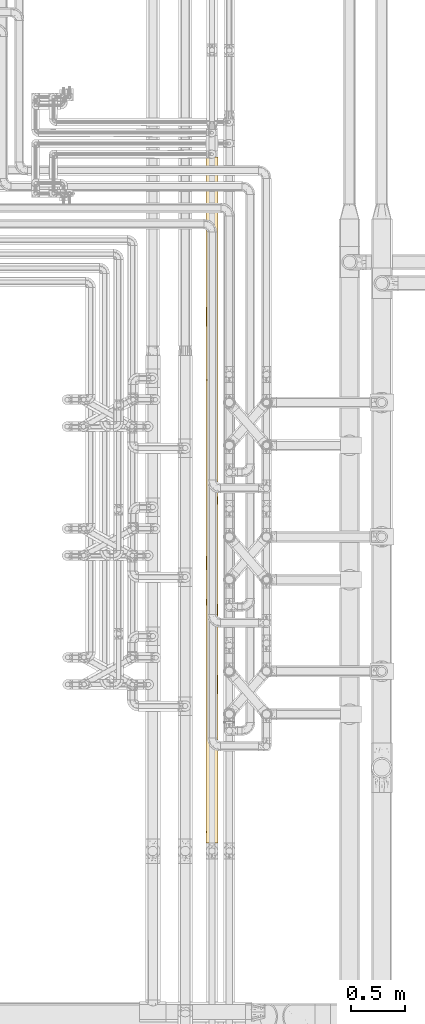
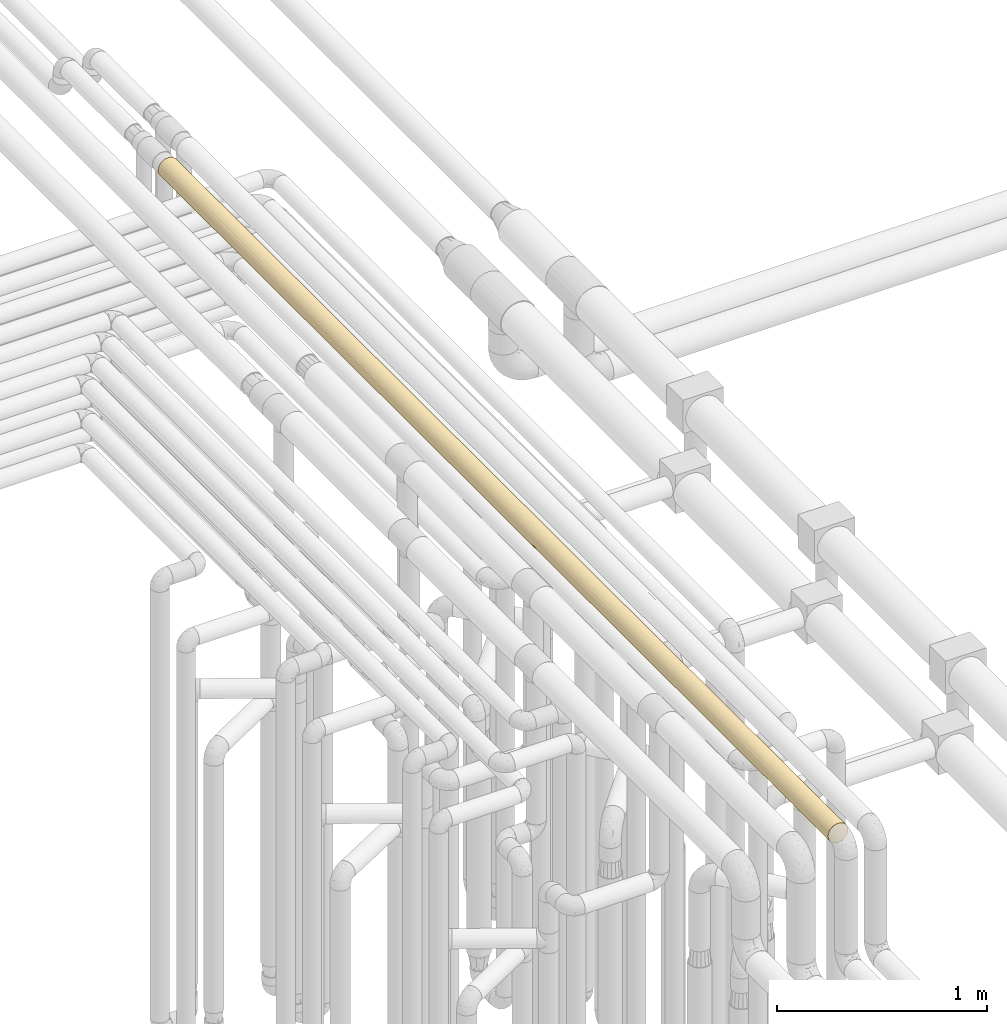
# One storey, part 36 of 827: 1 covering.
"""IFC2X3 building model written with IfcOpenShell, lengths in millimetres."""

import ifcopenshell
import ifcopenshell.guid

model = None  # the IFC model being written
_history = None  # IfcOwnerHistory: only IFC2X3 demands one
_inside = {}  # id of a spatial element -> (the spatial element, [elements in it])
_under = {}  # id of a project, library or spatial element -> (it, [spatial elements below it])
_declared = {}  # id of a project -> (the project, [libraries it declares])
_typed = {}  # id of a type object -> (the type object, [elements of that type])
_made_of = {}  # id of a material, layer set ... -> (it, [elements and type objects made of it])


def new_model(schema):
    """Start an empty IFC model of exactly this schema.

    Asked for "IFC4X3", IfcOpenShell would pick the latest addendum, in which some entities
    have other attributes; the version numbers below select the first issue.
    IFC2X3 requires an IfcOwnerHistory on every rooted entity: one is made here for all.
    """
    global model, _history
    if schema == "IFC4X3":
        model = ifcopenshell.file(schema_version=(4, 3, 0, 0))
    else:
        model = ifcopenshell.file(schema=schema)
    _inside.clear()
    _under.clear()
    _declared.clear()
    _typed.clear()
    _made_of.clear()
    _history = None
    if model.schema == "IFC2X3":
        org = make("IfcOrganization", Name="unknown")
        user = make(
            "IfcPersonAndOrganization",
            ThePerson=make("IfcPerson", FamilyName="unknown"),
            TheOrganization=org,
        )
        app = make(
            "IfcApplication",
            ApplicationDeveloper=org,
            Version="unknown",
            ApplicationFullName="unknown",
            ApplicationIdentifier="unknown",
        )
        _history = make(
            "IfcOwnerHistory",
            OwningUser=user,
            OwningApplication=app,
            ChangeAction="ADDED",
            CreationDate=0,
        )
    return model


def make(cls, **values):
    """One entity of the class cls with the attributes given. An attribute that is None is left unset."""
    return model.create_entity(
        cls, **{name: value for name, value in values.items() if value is not None}
    )


def entity(cls, *values):
    """Any entity or typed value of the class cls, its attributes in the order of the schema. None: left unset."""
    e = model.create_entity(cls)
    for i, value in enumerate(values):
        if value is not None:
            e[i] = value
    return e


def rooted(cls, **values):
    """An entity with a GlobalId (a new one), such as an element, a storey or a relation."""
    return make(cls, GlobalId=ifcopenshell.guid.new(), OwnerHistory=_history, **values)


def si_unit(unit_type, name, prefix=None):
    """IfcSIUnit, for example si_unit("LENGTHUNIT", "METRE", prefix="MILLI")."""
    return make("IfcSIUnit", UnitType=unit_type, Prefix=prefix, Name=name)


def converted_unit(unit_type, name, factor, base, dimensions=None, offset=None):
    """IfcConversionBasedUnit, such as the inch: factor (a typed value) times the base unit."""
    return make(
        "IfcConversionBasedUnit"
        if offset is None
        else "IfcConversionBasedUnitWithOffset",
        ConversionOffset=offset,
        Dimensions=None
        if dimensions is None
        else entity("IfcDimensionalExponents", *dimensions),
        UnitType=unit_type,
        Name=name,
        ConversionFactor=make(
            "IfcMeasureWithUnit", ValueComponent=factor, UnitComponent=base
        ),
    )


def derived_unit(unit_type, elements):
    """IfcDerivedUnit: a product of units, each with its exponent."""
    return make(
        "IfcDerivedUnit",
        Elements=[
            make("IfcDerivedUnitElement", Unit=unit, Exponent=power)
            for unit, power in elements
        ],
        UnitType=unit_type,
    )


def assignment(units):
    """IfcUnitAssignment: the units of a project."""
    return None if units is None else make("IfcUnitAssignment", Units=units)


def point(xyz):
    """IfcCartesianPoint."""
    return None if xyz is None else make("IfcCartesianPoint", Coordinates=xyz)


def direction(xyz):
    """IfcDirection."""
    return None if xyz is None else make("IfcDirection", DirectionRatios=xyz)


def frame(location, z_axis=None, x_axis=None):
    """IfcAxis2Placement3D, a coordinate frame: its origin and axes. An axis left out is left unset."""
    return make(
        "IfcAxis2Placement3D",
        Location=point(location),
        Axis=direction(z_axis),
        RefDirection=direction(x_axis),
    )


def origin():
    """The frame at (0, 0, 0) with its axes left unset."""
    return frame((0.0, 0.0, 0.0))


def place(relative_to, where):
    """IfcLocalPlacement: puts the frame where relative to a parent placement (None: the world)."""
    return make(
        "IfcLocalPlacement", PlacementRelTo=relative_to, RelativePlacement=where
    )


def context(
    kind, dimensions, precision=None, world=None, true_north=None, identifier=None
):
    """IfcGeometricRepresentationContext, for example the 3D "Model" context."""
    return make(
        "IfcGeometricRepresentationContext",
        ContextIdentifier=identifier,
        ContextType=kind,
        CoordinateSpaceDimension=dimensions,
        Precision=precision,
        WorldCoordinateSystem=world,
        TrueNorth=true_north,
    )


def subcontext(parent, identifier, kind, view, scale=None):
    """IfcGeometricRepresentationSubContext, for example "Body" below "Model"."""
    return make(
        "IfcGeometricRepresentationSubContext",
        ContextIdentifier=identifier,
        ContextType=kind,
        ParentContext=parent,
        TargetScale=scale,
        TargetView=view,
    )


def project(units=None, contexts=None):
    """IfcProject with its units and contexts."""
    return rooted(
        "IfcProject",
        Name="project",
        RepresentationContexts=contexts,
        UnitsInContext=assignment(units),
    )


def spatial(cls, under=None, at=None, **own):
    """A site, building, storey or space (cls), placed at a placement, below another one or the project."""
    s = rooted(cls, ObjectPlacement=at, **own)
    if under is not None:
        _under.setdefault(under.id(), (under, []))[1].append(s)
    return s


def faces_of(points, faces, orient=None, outer=None):
    """IfcFace entities. A face is a list of loops; a loop is a list of indices into points, from 0.

    orient and outer hold one flag for each loop. By default every Orientation is true, the
    first loop of a face is its IfcFaceOuterBound and the others are IfcFaceBound.
    """
    made = []
    for i, loops in enumerate(faces):
        bounds = []
        for j, loop in enumerate(loops):
            is_outer = j == 0 if outer is None else outer[i][j]
            bounds.append(
                make(
                    "IfcFaceOuterBound" if is_outer else "IfcFaceBound",
                    Bound=make("IfcPolyLoop", Polygon=[points[k] for k in loop]),
                    Orientation=True if orient is None else orient[i][j],
                )
            )
        made.append(make("IfcFace", Bounds=bounds))
    return made


def faceted_brep(points, faces, orient=None, outer=None, voids=None):
    """IfcFacetedBrep: a solid bounded by flat faces; with voids (closed shells), ...WithVoids."""
    shared = [point(p) for p in points]
    hull = make("IfcClosedShell", CfsFaces=faces_of(shared, faces, orient, outer))
    if voids is None:
        return make("IfcFacetedBrep", Outer=hull)
    return make(
        "IfcFacetedBrepWithVoids",
        Outer=hull,
        Voids=[
            make(cls, CfsFaces=faces_of(shared, fs, o, b)) for cls, fs, o, b in voids
        ],
    )


def shape(context_of_items, identifier, shape_type, items):
    """IfcShapeRepresentation: the items that make up one representation, for example the "Body"."""
    return make(
        "IfcShapeRepresentation",
        ContextOfItems=context_of_items,
        RepresentationIdentifier=identifier,
        RepresentationType=shape_type,
        Items=items,
    )


def made_of(thing, what):
    """Note that an element or type object is made of a material, layer set ...; save() writes the relation."""
    if what is not None:
        _made_of.setdefault(what.id(), (what, []))[1].append(thing)
    return thing


def element(
    cls,
    number,
    at=None,
    inside=None,
    cuts=None,
    type_object=None,
    material=None,
    context=None,
    identifier="Body",
    shape_type=None,
    held_by="IfcProductDefinitionShape",
    body=None,
    shapes=None,
    **own,
):
    """One element of the class cls, such as IfcWall. Its Tag is "e" and its number.

    at: its placement. inside: the storey or other place that contains it. cuts: it is an
    opening in that element (IfcRelVoidsElement). A single representation is given by context,
    identifier, shape_type and body (its items); several are given by shapes. held_by: the class
    of the entity that holds the representations. save() writes the other relations.
    """
    e = rooted(cls, Tag="e%d" % number, ObjectPlacement=at, **own)
    if body is not None:
        shapes = [shape(context, identifier, shape_type, body)]
    if shapes is not None:
        e.Representation = make(held_by, Representations=shapes)
    if inside is not None:
        _inside.setdefault(inside.id(), (inside, []))[1].append(e)
    if cuts is not None:
        rooted(
            "IfcRelVoidsElement", RelatingBuildingElement=cuts, RelatedOpeningElement=e
        )
    if type_object is not None:
        _typed.setdefault(type_object.id(), (type_object, []))[1].append(e)
    return made_of(e, material)


def aggregate(whole, parts):
    """IfcRelAggregates: a whole, such as a stair, and the parts it consists of."""
    return rooted("IfcRelAggregates", RelatingObject=whole, RelatedObjects=parts)


def save(model, path):
    """Write the relations noted so far, then the file.

    IfcRelAggregates (storeys below a building ...), IfcRelContainedInSpatialStructure (elements
    in a storey), IfcRelDefinesByType, IfcRelAssociatesMaterial and IfcRelDeclares: one each for
    every whole, place, type object, material and project.
    """
    for whole, parts in _under.values():
        aggregate(whole, parts)
    for where, things in _inside.values():
        rooted(
            "IfcRelContainedInSpatialStructure",
            RelatedElements=things,
            RelatingStructure=where,
        )
    for kind, things in _typed.values():
        rooted("IfcRelDefinesByType", RelatedObjects=things, RelatingType=kind)
    for what, things in _made_of.values():
        rooted("IfcRelAssociatesMaterial", RelatedObjects=things, RelatingMaterial=what)
    for by, libraries in _declared.values():
        rooted("IfcRelDeclares", RelatingContext=by, RelatedDefinitions=libraries)
    model.write(path)


model = new_model("IFC2X3")

# Units and contexts
model_context = context("Model", 3, precision=0.01, world=origin(), true_north=direction((6.12303176911189e-17, 1.0)))
body_context = subcontext(model_context, "Body", "Model", "MODEL_VIEW")
ifc_project = project(units=[si_unit("LENGTHUNIT", "METRE", prefix="MILLI"), si_unit("AREAUNIT", "SQUARE_METRE"), si_unit("VOLUMEUNIT", "CUBIC_METRE"), converted_unit("PLANEANGLEUNIT", "DEGREE", entity("IfcRatioMeasure", 0.0174532925199433), si_unit("PLANEANGLEUNIT", "RADIAN"), dimensions=[0, 0, 0, 0, 0, 0, 0]), si_unit("MASSUNIT", "GRAM", prefix="KILO"), derived_unit("MASSDENSITYUNIT", [(si_unit("MASSUNIT", "GRAM", prefix="KILO"), 1), (si_unit("LENGTHUNIT", "METRE"), -3)]), derived_unit("MOMENTOFINERTIAUNIT", [(si_unit("LENGTHUNIT", "METRE"), 4)]), si_unit("TIMEUNIT", "SECOND"), si_unit("FREQUENCYUNIT", "HERTZ"), si_unit("THERMODYNAMICTEMPERATUREUNIT", "DEGREE_CELSIUS"), derived_unit("THERMALTRANSMITTANCEUNIT", [(si_unit("MASSUNIT", "GRAM", prefix="KILO"), 1), (si_unit("THERMODYNAMICTEMPERATUREUNIT", "KELVIN"), -1), (si_unit("TIMEUNIT", "SECOND"), -3)]), derived_unit("VOLUMETRICFLOWRATEUNIT", [(si_unit("LENGTHUNIT", "METRE"), 3), (si_unit("TIMEUNIT", "SECOND"), -1)]), derived_unit("MASSFLOWRATEUNIT", [(si_unit("MASSUNIT", "GRAM", prefix="KILO"), 1), (si_unit("TIMEUNIT", "SECOND"), -1)]), derived_unit("ROTATIONALFREQUENCYUNIT", [(si_unit("TIMEUNIT", "SECOND"), -1)]), si_unit("ELECTRICCURRENTUNIT", "AMPERE"), si_unit("ELECTRICVOLTAGEUNIT", "VOLT"), si_unit("POWERUNIT", "WATT"), si_unit("FORCEUNIT", "NEWTON", prefix="KILO"), si_unit("ILLUMINANCEUNIT", "LUX"), si_unit("LUMINOUSFLUXUNIT", "LUMEN"), si_unit("LUMINOUSINTENSITYUNIT", "CANDELA"), derived_unit("USERDEFINED", [(si_unit("MASSUNIT", "GRAM", prefix="KILO"), -1), (si_unit("LENGTHUNIT", "METRE"), -2), (si_unit("TIMEUNIT", "SECOND"), 3), (si_unit("LUMINOUSFLUXUNIT", "LUMEN"), 1)]), derived_unit("LINEARVELOCITYUNIT", [(si_unit("LENGTHUNIT", "METRE"), 1), (si_unit("TIMEUNIT", "SECOND"), -1)]), si_unit("PRESSUREUNIT", "PASCAL"), derived_unit("USERDEFINED", [(si_unit("LENGTHUNIT", "METRE"), -2), (si_unit("MASSUNIT", "GRAM", prefix="KILO"), 1), (si_unit("TIMEUNIT", "SECOND"), -2)]), derived_unit("LINEARFORCEUNIT", [(si_unit("MASSUNIT", "GRAM", prefix="KILO"), 1), (si_unit("LENGTHUNIT", "METRE"), 1), (si_unit("TIMEUNIT", "SECOND"), -2), (si_unit("LENGTHUNIT", "METRE"), -1)]), derived_unit("PLANARFORCEUNIT", [(si_unit("MASSUNIT", "GRAM", prefix="KILO"), 1), (si_unit("LENGTHUNIT", "METRE"), 1), (si_unit("TIMEUNIT", "SECOND"), -2), (si_unit("LENGTHUNIT", "METRE"), -2)])], contexts=[model_context])

# Site, building, storey
site_placement = place(None, origin())
site = spatial("IfcSite", under=ifc_project, at=site_placement, CompositionType="ELEMENT")
building_placement = place(site_placement, origin())
building = spatial("IfcBuilding", under=site, at=building_placement, CompositionType="ELEMENT")
storey_placement = place(building_placement, frame((0.0, 0.0, 28200.0)))
storey = spatial("IfcBuildingStorey", under=building, at=storey_placement, Name="08", CompositionType="ELEMENT", Elevation=28200.0)

# Covering
covering_placement = place(storey_placement, frame((36412.12, 8883.39, 3493.4)))
element("IfcCovering", 1, at=covering_placement, inside=storey, Name=":ADSK_", ObjectType=":ADSK_", PredefinedType="INSULATION", context=body_context, shape_type="Brep", body=[
    faceted_brep([(42.36, 0.0, 3.47), (56.6, 0.0, 1.6), (70.83, 0.0, 3.47), (84.1, 0.0, 8.96), (95.49, 0.0, 17.7), (104.23, 0.0, 29.1), (109.72, 0.0, 42.36), (111.6, 0.0, 56.6), (109.72, 0.0, 70.83), (104.23, 0.0, 84.1), (95.49, 0.0, 95.49), (84.1, 0.0, 104.23), (70.83, 0.0, 109.72), (56.6, 0.0, 111.6), (42.36, 0.0, 109.72), (29.1, 0.0, 104.23), (17.7, 0.0, 95.49), (8.96, 0.0, 84.1), (3.47, 0.0, 70.83), (1.6, 0.0, 56.6), (3.47, 0.0, 42.36), (8.96, 0.0, 29.1), (17.7, 0.0, 17.7), (29.1, 0.0, 8.96), (18.1, 6379.11, 17.31), (11.1, 6379.11, 25.69), (5.89, 6379.11, 35.29), (2.68, 6379.11, 45.71), (1.6, 6379.11, 56.6), (3.47, 6379.11, 70.83), (8.96, 6379.11, 84.1), (17.7, 6379.11, 95.49), (29.1, 6379.11, 104.23), (42.36, 6379.11, 109.72), (56.6, 6379.11, 111.6), (70.83, 6379.11, 109.72), (84.1, 6379.11, 104.23), (95.49, 6379.11, 95.49), (104.23, 6379.11, 84.1), (109.72, 6379.11, 70.83), (111.6, 6379.11, 56.6), (110.51, 6379.11, 45.71), (107.3, 6379.11, 35.29), (102.09, 6379.11, 25.69), (95.09, 6379.11, 17.31), (8.26, 6120.78, 30.36), (29.57, 3792.49, 8.7), (20.71, 3875.0, 14.91), (28.5, 4063.4, 9.31), (32.4, 4961.16, 7.2), (43.56, 5179.68, 3.16), (45.19, 4861.42, 2.79), (35.81, 6370.97, 5.68), (30.84, 5993.61, 8.0), (26.39, 6374.44, 10.63), (3.2, 5598.65, 43.42), (7.32, 5293.74, 32.16), (3.24, 5269.84, 43.25), (1.6, 5861.21, 56.6), (4.03, 6038.59, 40.42), (5.78, 306.15, 35.55), (21.91, 5989.4, 13.91), (13.85, 5971.06, 21.98), (18.15, 5656.18, 17.26), (8.26, 5821.34, 30.36), (10.9, 4991.79, 25.99), (14.39, 5329.21, 21.33), (40.73, 5982.39, 3.93), (44.29, 5574.42, 2.99), (30.72, 5696.54, 8.06), (19.66, 4957.15, 15.84), (26.5, 1416.74, 10.56), (23.11, 978.81, 12.96), (14.79, 1285.53, 20.85), (7.37, 2118.12, 32.07), (12.18, 2630.58, 24.15), (18.35, 2216.18, 17.07), (56.6, 517.9, 1.6), (46.97, 311.86, 2.44), (46.04, 623.46, 2.62), (23.11, 352.85, 12.96), (2.41, 307.2, 47.18), (2.62, 615.17, 46.05), (1.6, 517.9, 56.6), (25.81, 4656.66, 11.02), (31.89, 4371.29, 7.46), (21.59, 4316.23, 14.17), (35.55, 239.04, 5.78), (46.0, 6368.83, 2.62), (25.85, 665.83, 10.99), (12.73, 853.03, 23.42), (12.96, 424.64, 23.11), (3.11, 1395.56, 43.79), (1.6, 1035.81, 56.6), (1.6, 1335.83, 56.6), (1.6, 1553.71, 56.6), (25.03, 5340.2, 11.55), (56.6, 6368.11, 1.6), (56.6, 5850.21, 1.6), (6.21, 1112.54, 34.54), (7.62, 1545.04, 31.56), (38.89, 807.52, 4.52), (38.77, 1083.03, 4.56), (56.6, 5332.3, 1.6), (3.15, 1812.66, 43.61), (3.01, 2174.03, 44.18), (9.07, 3483.93, 28.91), (9.44, 4015.28, 28.29), (15.38, 3484.51, 20.18), (21.79, 2714.4, 14.01), (1.6, 5343.3, 56.6), (7.99, 4282.11, 30.86), (4.9, 4640.07, 37.82), (10.09, 4553.55, 27.24), (37.74, 3903.0, 4.93), (47.58, 3908.07, 2.34), (44.37, 3519.64, 2.97), (13.48, 4272.94, 22.44), (5.78, 671.54, 35.55), (35.55, 550.38, 5.78), (35.13, 5390.59, 5.96), (56.6, 4814.4, 1.6), (41.72, 4555.45, 3.64), (28.12, 1866.4, 9.54), (32.27, 2337.38, 7.27), (16.06, 1735.19, 19.42), (40.3, 1594.67, 4.06), (16.92, 4652.15, 18.51), (56.6, 4296.5, 1.6), (42.02, 4217.43, 3.56), (56.6, 4037.54, 1.6), (28.5, 3521.58, 9.31), (5.55, 2500.61, 36.13), (11.44, 3075.13, 25.2), (6.53, 3227.43, 33.82), (2.75, 1081.94, 45.36), (1.6, 1635.84, 56.6), (1.6, 1935.86, 56.6), (1.6, 2071.61, 56.6), (9.66, 1834.96, 27.93), (22.38, 3110.76, 13.54), (2.48, 2490.84, 46.76), (1.6, 2630.58, 56.6), (4.31, 2910.07, 39.53), (33.41, 2825.05, 6.72), (44.73, 2784.71, 2.89), (44.55, 2358.81, 2.93), (41.0, 2011.21, 3.85), (56.6, 1927.61, 1.6), (56.6, 1333.08, 1.6), (56.6, 1035.81, 1.6), (1.6, 2910.07, 56.6), (2.93, 3215.03, 44.55), (3.81, 3904.91, 41.13), (1.6, 4028.01, 56.6), (4.13, 4308.44, 40.11), (1.6, 4825.4, 56.6), (1.6, 4307.5, 56.6), (43.05, 3115.34, 3.29), (4.6, 3506.67, 38.67), (1.6, 3469.04, 56.6), (56.6, 1630.34, 1.6), (56.6, 1553.71, 1.6), (56.6, 2224.88, 1.6), (4.83, 4978.34, 38.0), (56.6, 3260.69, 1.6), (56.6, 3778.59, 1.6), (56.6, 3740.28, 1.6), (56.6, 3462.17, 1.6), (32.16, 3146.54, 7.32), (56.6, 3184.05, 1.6), (56.6, 2905.94, 1.6), (56.6, 2742.79, 1.6), (56.6, 4018.39, 1.6), (56.6, 2627.83, 1.6), (56.6, 2349.72, 1.6), (1.6, 2351.1, 56.6), (1.6, 2235.88, 56.6), (1.6, 2753.78, 56.6), (1.6, 3748.53, 56.6), (1.6, 3189.56, 56.6), (1.6, 3271.69, 56.6), (56.6, 2071.61, 1.6), (1.6, 3789.59, 56.6), (77.38, 6370.97, 5.68), (86.8, 6374.44, 10.63), (82.31, 6116.37, 7.98), (105.67, 4380.67, 31.75), (98.87, 4318.89, 21.41), (101.9, 4663.76, 25.42), (72.44, 6033.51, 3.93), (98.8, 5990.77, 21.33), (78.65, 1112.54, 6.21), (81.63, 1545.04, 7.62), (92.34, 1285.53, 14.79), (109.16, 5990.84, 40.42), (104.93, 6007.86, 30.36), (104.94, 5704.49, 30.36), (90.71, 5971.71, 13.46), (98.12, 3878.29, 20.53), (103.77, 4070.04, 28.33), (104.54, 3801.94, 29.64), (77.64, 306.15, 5.78), (81.02, 5454.94, 7.32), (69.58, 5600.86, 3.15), (82.42, 5820.55, 8.03), (110.13, 5579.28, 43.99), (87.11, 5001.09, 10.84), (91.57, 5337.31, 14.14), (97.18, 4970.47, 19.48), (101.33, 5354.27, 24.6), (72.0, 5297.1, 3.8), (69.4, 1395.56, 3.11), (100.23, 352.85, 23.11), (102.65, 1417.64, 26.53), (100.23, 978.81, 23.11), (90.08, 424.64, 12.96), (95.46, 5662.2, 17.68), (81.15, 2116.19, 7.38), (83.7, 2395.32, 8.74), (96.15, 2216.3, 18.38), (66.01, 307.2, 2.41), (107.41, 239.04, 35.55), (89.77, 853.03, 12.73), (102.2, 665.83, 25.85), (67.14, 615.17, 2.62), (105.83, 4967.53, 32.09), (110.03, 5179.62, 43.55), (110.43, 4866.29, 45.32), (67.19, 6368.83, 2.62), (111.6, 517.9, 56.6), (110.75, 311.86, 46.97), (110.57, 623.46, 46.04), (111.6, 5861.21, 56.6), (108.67, 807.48, 38.89), (108.63, 1082.97, 38.77), (111.6, 5343.3, 56.6), (70.18, 2137.69, 3.3), (71.46, 2461.07, 3.64), (84.39, 3484.39, 9.14), (85.05, 4007.62, 9.53), (93.16, 3482.16, 15.51), (88.98, 2627.83, 12.14), (99.08, 2727.49, 21.67), (82.18, 4267.78, 7.91), (74.25, 4644.9, 4.5), (85.48, 4554.0, 9.79), (108.26, 3913.48, 37.74), (110.85, 3919.07, 47.58), (110.22, 3530.64, 44.38), (90.52, 4276.3, 13.3), (77.64, 671.54, 5.78), (107.41, 550.38, 35.55), (107.12, 5387.52, 34.85), (111.6, 4825.4, 56.6), (109.53, 4566.45, 41.68), (93.79, 1736.2, 16.08), (103.68, 1868.31, 28.17), (105.96, 2341.21, 32.34), (109.13, 1595.61, 40.32), (94.25, 4665.52, 16.5), (111.6, 4307.5, 56.6), (109.59, 4228.85, 41.89), (111.6, 4048.54, 56.6), (103.92, 3532.72, 28.57), (99.97, 3123.9, 22.78), (88.56, 3070.43, 11.84), (79.68, 3222.11, 6.68), (67.83, 1081.94, 2.75), (69.58, 1812.66, 3.15), (85.28, 1833.86, 9.67), (73.62, 2905.94, 4.3), (106.46, 2831.02, 33.39), (110.3, 2794.03, 44.72), (110.25, 2359.41, 44.52), (109.37, 2013.77, 41.11), (111.6, 1935.86, 56.6), (111.6, 1335.83, 56.6), (111.6, 1035.81, 56.6), (109.89, 3124.59, 43.0), (68.68, 3213.41, 2.94), (79.5, 2654.56, 6.59), (72.62, 3896.41, 3.98), (73.03, 4290.31, 4.11), (74.57, 3506.47, 4.62), (111.6, 1635.85, 56.6), (111.6, 1553.71, 56.6), (111.6, 2235.88, 56.6), (111.6, 3271.69, 56.6), (111.6, 3789.59, 56.6), (111.6, 3748.52, 56.6), (111.6, 3469.04, 56.6), (105.98, 3144.32, 32.38), (111.6, 3189.55, 56.6), (111.6, 2910.07, 56.6), (111.6, 2753.79, 56.6), (111.6, 4028.01, 56.6), (75.23, 5000.09, 4.85), (111.6, 2630.58, 56.6), (111.6, 2351.1, 56.6), (111.6, 2071.61, 56.6), (90.08, 5954.47, 100.23), (100.23, 6026.26, 90.08), (110.08, 1395.56, 69.4), (107.41, 306.15, 77.64), (100.23, 424.64, 90.08), (110.78, 307.2, 66.01), (110.58, 615.17, 67.14), (102.43, 4972.92, 87.0), (100.23, 5400.3, 90.08), (92.34, 5093.58, 98.4), (77.64, 6072.96, 107.41), (110.47, 3608.78, 67.65), (66.01, 6071.91, 110.78), (67.14, 5763.94, 110.58), (102.2, 5713.28, 87.34), (89.77, 5526.08, 100.46), (78.65, 5266.57, 106.98), (81.63, 4834.07, 105.57), (90.08, 352.85, 100.23), (86.66, 1417.64, 102.65), (90.08, 978.81, 100.23), (98.4, 1285.53, 92.34), (110.25, 3264.05, 68.69), (107.41, 6140.07, 77.64), (56.6, 517.9, 111.6), (66.22, 311.86, 110.75), (67.15, 623.46, 110.57), (77.64, 239.04, 107.41), (100.46, 853.03, 89.77), (87.34, 665.83, 102.2), (109.07, 4795.35, 73.06), (108.84, 4411.83, 73.78), (56.6, 5861.21, 111.6), (69.4, 4983.55, 110.08), (56.6, 5343.3, 111.6), (56.6, 4825.4, 111.6), (110.75, 6067.25, 66.22), (110.57, 5755.65, 67.15), (106.98, 1112.54, 78.65), (105.57, 1545.04, 81.63), (108.67, 5571.02, 74.3), (108.63, 5295.03, 74.42), (74.3, 807.48, 108.67), (74.42, 1082.97, 108.63), (84.37, 4486.3, 104.07), (93.54, 4655.78, 97.34), (56.6, 3789.59, 111.6), (69.01, 3862.21, 110.17), (68.41, 4229.1, 110.31), (94.73, 2205.5, 96.23), (92.08, 2600.18, 98.62), (80.34, 2356.74, 106.21), (105.52, 2077.57, 81.72), (101.89, 2572.71, 87.79), (77.64, 5707.57, 107.41), (107.41, 5828.73, 77.64), (107.41, 671.54, 77.64), (77.64, 550.38, 107.41), (110.06, 2193.08, 69.49), (110.04, 1812.66, 69.58), (97.11, 1736.2, 93.79), (85.02, 1868.31, 103.68), (72.87, 1595.61, 109.13), (103.3, 4535.12, 85.65), (101.08, 3468.31, 88.93), (107.15, 3469.04, 78.25), (104.4, 3797.29, 83.78), (67.83, 5297.17, 110.44), (69.58, 4566.45, 110.04), (56.6, 4307.5, 111.6), (88.31, 4232.76, 101.53), (97.55, 4406.23, 93.3), (85.21, 3255.64, 103.57), (93.08, 3552.07, 97.76), (79.58, 3689.88, 106.56), (88.92, 3869.34, 101.09), (79.73, 4158.66, 106.49), (107.01, 2402.04, 78.59), (97.15, 3818.83, 93.75), (108.68, 4028.01, 74.26), (108.9, 2910.07, 73.6), (100.95, 3087.04, 89.11), (103.53, 4154.32, 85.27), (95.55, 4122.37, 95.43), (67.71, 3509.57, 110.46), (110.44, 1081.94, 67.83), (103.32, 1810.62, 85.62), (110.42, 2523.76, 67.92), (92.93, 2954.41, 97.88), (82.79, 2861.2, 104.96), (70.41, 2746.9, 109.83), (71.37, 3132.85, 109.57), (56.6, 2753.79, 111.6), (72.03, 2015.77, 109.39), (56.6, 1935.86, 111.6), (56.6, 1335.82, 111.6), (56.6, 1035.81, 111.6), (56.6, 1635.84, 111.6), (56.6, 1553.71, 111.6), (107.1, 3171.61, 78.38), (94.83, 3252.62, 96.13), (68.43, 2349.94, 110.31), (56.6, 2235.88, 111.6), (56.6, 3271.69, 111.6), (56.6, 3189.56, 111.6), (56.6, 2910.07, 111.6), (56.6, 3748.53, 111.6), (56.6, 3469.04, 111.6), (56.6, 2630.58, 111.6), (56.6, 2351.1, 111.6), (56.6, 2071.62, 111.6), (56.6, 4028.01, 111.6), (12.96, 5954.47, 90.08), (23.11, 6026.26, 100.23), (43.79, 1395.56, 110.08), (35.55, 306.15, 107.41), (23.11, 424.64, 100.23), (47.18, 307.2, 110.78), (46.05, 615.17, 110.58), (26.19, 4972.92, 102.43), (23.11, 5400.3, 100.23), (14.79, 5093.58, 92.34), (5.78, 6072.96, 77.64), (45.54, 3608.78, 110.47), (2.41, 6071.91, 66.01), (2.62, 5763.94, 67.14), (25.85, 5713.28, 102.2), (12.73, 5526.08, 89.77), (6.21, 5266.57, 78.65), (7.62, 4834.07, 81.63), (12.96, 352.85, 90.08), (10.54, 1417.64, 86.66), (12.96, 978.81, 90.08), (20.85, 1285.53, 98.4), (44.5, 3264.05, 110.25), (35.55, 6140.07, 107.41), (2.44, 311.86, 66.22), (2.62, 623.46, 67.15), (5.78, 239.04, 77.64), (23.42, 853.03, 100.46), (10.99, 665.83, 87.34), (40.13, 4795.35, 109.07), (39.41, 4411.83, 108.84), (3.11, 4983.55, 69.4), (46.97, 6067.25, 110.75), (46.04, 5755.65, 110.57), (34.54, 1112.54, 106.98), (31.56, 1545.04, 105.57), (38.89, 5571.02, 108.67), (38.77, 5295.03, 108.63), (4.52, 807.48, 74.3), (4.56, 1082.97, 74.42), (9.12, 4486.3, 84.37), (15.85, 4655.78, 93.54), (3.02, 3862.21, 69.01), (2.88, 4229.1, 68.41), (16.96, 2205.5, 94.73), (14.57, 2600.18, 92.08), (6.98, 2356.74, 80.34), (31.47, 2077.57, 105.52), (25.4, 2572.71, 101.89), (5.78, 5707.57, 77.64), (35.55, 5828.73, 107.41), (35.55, 671.54, 107.41), (5.78, 550.38, 77.64), (43.7, 2193.08, 110.06), (43.61, 1812.66, 110.04), (19.4, 1736.2, 97.11), (9.51, 1868.31, 85.02), (4.06, 1595.61, 72.87), (27.54, 4535.12, 103.3), (24.26, 3468.31, 101.08), (34.94, 3469.04, 107.15), (29.41, 3797.29, 104.4), (2.75, 5297.17, 67.83), (3.15, 4566.45, 69.58), (11.66, 4232.76, 88.31), (19.89, 4406.23, 97.55), (9.62, 3255.64, 85.21), (15.43, 3552.07, 93.08), (6.63, 3689.88, 79.58), (12.1, 3869.34, 88.92), (6.7, 4158.66, 79.73), (34.61, 2402.04, 107.01), (19.44, 3818.83, 97.15), (38.93, 4028.01, 108.68), (39.59, 2910.07, 108.9), (24.08, 3087.04, 100.95), (27.92, 4154.32, 103.53), (17.76, 4122.37, 95.55), (2.73, 3509.57, 67.71), (45.36, 1081.94, 110.44), (27.57, 1810.62, 103.32), (15.31, 2954.41, 92.93), (8.24, 2861.2, 82.79), (3.36, 2746.9, 70.41), (3.62, 3132.85, 71.37), (3.81, 2015.77, 72.03), (34.81, 3171.61, 107.1), (17.06, 3252.62, 94.83), (2.88, 2349.94, 68.43), (45.27, 2523.76, 110.42)], [[[0, 1, 2, 3, 4, 5, 6, 7, 8, 9, 10, 11, 12, 13, 14, 15, 16, 17, 18, 19, 20, 21, 22, 23]], [[24, 25, 26, 27, 28, 29, 30, 31, 32, 33, 34, 35, 36, 37, 38, 39, 40, 41, 42, 43, 44]], [[26, 25, 45]], [[46, 47, 48]], [[49, 50, 51]], [[52, 53, 54]], [[55, 56, 57]], [[27, 58, 28]], [[26, 45, 59]], [[21, 20, 60]], [[61, 24, 54]], [[62, 63, 64]], [[65, 56, 66]], [[67, 68, 69]], [[65, 66, 70]], [[71, 72, 73]], [[74, 75, 76]], [[77, 78, 79]], [[22, 80, 23]], [[60, 81, 82]], [[19, 83, 81]], [[84, 85, 86]], [[69, 53, 67]], [[87, 0, 23]], [[52, 88, 67]], [[72, 89, 90]], [[91, 80, 22]], [[92, 93, 94, 95]], [[96, 70, 66]], [[61, 53, 69]], [[62, 24, 61]], [[21, 60, 91]], [[55, 58, 59]], [[26, 59, 27]], [[88, 97, 98]], [[99, 100, 73]], [[21, 91, 22]], [[101, 72, 102]], [[0, 87, 78]], [[63, 66, 64]], [[62, 64, 45]], [[88, 98, 67]], [[68, 98, 103]], [[104, 105, 74]], [[72, 90, 73]], [[106, 107, 108]], [[75, 109, 76]], [[55, 59, 64]], [[58, 27, 59]], [[56, 64, 66]], [[58, 55, 110]], [[66, 63, 96]], [[111, 112, 113]], [[114, 115, 116]], [[117, 107, 111]], [[90, 91, 118]], [[60, 82, 118]], [[80, 89, 119]], [[68, 50, 120]], [[0, 78, 1]], [[121, 122, 51]], [[98, 68, 67]], [[123, 76, 124]], [[68, 103, 50]], [[71, 125, 123]], [[126, 71, 123]], [[91, 90, 89]], [[87, 80, 119]], [[25, 24, 62]], [[59, 45, 64]], [[62, 45, 25]], [[62, 61, 63]], [[61, 69, 63]], [[96, 63, 69]], [[120, 69, 68]], [[70, 96, 49]], [[49, 84, 70]], [[84, 127, 70]], [[121, 128, 122]], [[129, 114, 48]], [[122, 85, 84]], [[129, 128, 130]], [[46, 116, 131]], [[74, 132, 75]], [[106, 133, 134]], [[121, 50, 103]], [[120, 49, 96]], [[81, 60, 20]], [[91, 60, 118]], [[99, 90, 118]], [[90, 99, 73]], [[135, 118, 82]], [[99, 92, 100]], [[125, 73, 100]], [[104, 95, 136, 137, 138]], [[73, 125, 71]], [[139, 125, 100]], [[76, 123, 125]], [[104, 100, 92]], [[140, 133, 108]], [[76, 125, 139]], [[141, 142, 143]], [[109, 75, 133]], [[131, 140, 108]], [[144, 145, 146]], [[147, 148, 126]], [[102, 72, 71]], [[102, 71, 126]], [[102, 126, 149]], [[150, 77, 79]], [[123, 124, 147]], [[150, 102, 149]], [[151, 152, 143]], [[132, 74, 105]], [[153, 154, 155]], [[117, 47, 107]], [[155, 111, 153]], [[156, 112, 157]], [[158, 145, 144]], [[123, 147, 126]], [[105, 104, 138]], [[139, 104, 74]], [[159, 152, 160]], [[19, 81, 20]], [[81, 83, 82]], [[83, 93, 82]], [[126, 148, 161, 162, 149]], [[82, 93, 135]], [[146, 147, 124]], [[146, 163, 147]], [[117, 111, 113]], [[112, 65, 113]], [[135, 92, 99]], [[104, 92, 95]], [[65, 70, 127]], [[56, 65, 164]], [[57, 56, 164]], [[64, 56, 55]], [[57, 164, 156]], [[110, 55, 57]], [[122, 84, 49]], [[86, 117, 127]], [[129, 85, 122]], [[85, 129, 48]], [[122, 128, 129]], [[129, 130, 115]], [[165, 158, 116]], [[116, 166, 167, 168, 165]], [[169, 158, 144]], [[116, 158, 169]], [[47, 131, 108]], [[109, 140, 144]], [[140, 109, 133]], [[75, 143, 133]], [[143, 152, 134]], [[158, 165, 170, 171, 172]], [[144, 140, 169]], [[107, 47, 108]], [[86, 85, 48]], [[115, 130, 173, 166]], [[116, 115, 166]], [[129, 115, 114]], [[86, 127, 84]], [[65, 127, 113]], [[144, 146, 124]], [[146, 172, 174, 175, 163]], [[144, 124, 109]], [[76, 109, 124]], [[106, 153, 107]], [[57, 156, 110]], [[156, 164, 112]], [[106, 134, 159]], [[154, 157, 155]], [[49, 120, 50]], [[69, 120, 96]], [[158, 172, 145]], [[146, 145, 172]], [[141, 176, 142]], [[141, 143, 132]], [[176, 141, 105]], [[143, 75, 132]], [[105, 138, 177, 176]], [[143, 142, 178, 151]], [[105, 141, 132]], [[135, 99, 118]], [[93, 92, 135]], [[140, 131, 169]], [[116, 169, 131]], [[80, 87, 23]], [[119, 79, 78]], [[119, 78, 87]], [[1, 78, 77]], [[119, 101, 79]], [[79, 101, 150]], [[101, 119, 89]], [[150, 101, 102]], [[54, 53, 61]], [[52, 67, 53]], [[89, 80, 91]], [[101, 89, 72]], [[49, 51, 122]], [[50, 121, 51]], [[104, 139, 100]], [[76, 139, 74]], [[160, 179, 159]], [[152, 151, 180, 181, 160]], [[134, 152, 159]], [[179, 153, 159]], [[143, 134, 133]], [[106, 159, 153]], [[133, 106, 108]], [[147, 163, 182, 148]], [[127, 117, 113]], [[47, 117, 86]], [[153, 111, 107]], [[111, 155, 112]], [[46, 48, 114]], [[86, 48, 47]], [[116, 46, 114]], [[47, 46, 131]], [[112, 155, 157]], [[65, 112, 164]], [[153, 179, 183, 154]], [[184, 185, 186]], [[187, 188, 189]], [[184, 186, 190]], [[191, 44, 43]], [[192, 193, 194]], [[195, 196, 42]], [[196, 195, 197]], [[198, 44, 191]], [[199, 200, 201]], [[3, 2, 202]], [[203, 204, 205]], [[197, 195, 206]], [[207, 208, 209]], [[210, 209, 208]], [[211, 204, 203]], [[212, 150, 149, 162]], [[4, 213, 5]], [[214, 215, 194]], [[3, 202, 216]], [[216, 213, 4]], [[205, 198, 217]], [[218, 219, 220]], [[1, 77, 221]], [[222, 6, 5]], [[223, 215, 224]], [[202, 221, 225]], [[226, 227, 228]], [[98, 97, 229]], [[42, 41, 195]], [[230, 231, 232]], [[190, 204, 98]], [[184, 190, 229]], [[191, 196, 197]], [[41, 40, 233]], [[3, 216, 4]], [[234, 215, 235]], [[6, 222, 231]], [[208, 203, 217]], [[198, 205, 186]], [[41, 233, 195]], [[206, 233, 236]], [[204, 190, 205]], [[98, 229, 190]], [[237, 175, 238]], [[215, 223, 194]], [[239, 240, 241]], [[242, 243, 220]], [[205, 217, 203]], [[103, 98, 204]], [[208, 217, 210]], [[244, 245, 246]], [[247, 248, 249]], [[250, 240, 244]], [[223, 216, 251]], [[202, 225, 251]], [[213, 224, 252]], [[206, 227, 253]], [[6, 231, 7]], [[254, 255, 228]], [[214, 256, 257]], [[257, 220, 258]], [[259, 214, 257]], [[233, 206, 195]], [[206, 236, 227]], [[216, 223, 224]], [[222, 213, 252]], [[185, 44, 198]], [[190, 186, 205]], [[198, 186, 185]], [[198, 191, 217]], [[191, 197, 217]], [[210, 217, 197]], [[253, 197, 206]], [[209, 210, 226]], [[226, 189, 209]], [[189, 260, 209]], [[254, 261, 255]], [[262, 247, 200]], [[255, 187, 189]], [[262, 261, 263]], [[201, 249, 264]], [[265, 266, 241]], [[239, 266, 267]], [[254, 227, 236]], [[253, 226, 210]], [[221, 202, 2]], [[216, 202, 251]], [[192, 223, 251]], [[223, 192, 194]], [[268, 251, 225]], [[192, 212, 193]], [[256, 194, 193]], [[269, 162, 161, 148, 182]], [[194, 256, 214]], [[270, 256, 193]], [[220, 257, 256]], [[269, 193, 212]], [[271, 238, 174]], [[271, 174, 172, 171]], [[220, 256, 270]], [[243, 242, 266]], [[264, 265, 241]], [[272, 273, 274]], [[275, 276, 259]], [[235, 215, 214]], [[235, 214, 259]], [[235, 259, 277]], [[278, 230, 232]], [[279, 273, 272]], [[257, 275, 259]], [[257, 258, 275]], [[278, 235, 277]], [[171, 280, 271]], [[219, 238, 281]], [[282, 173, 283]], [[250, 199, 240]], [[283, 244, 282]], [[121, 245, 128]], [[218, 237, 238]], [[270, 269, 218]], [[284, 280, 168]], [[1, 221, 2]], [[221, 77, 225]], [[250, 244, 246]], [[245, 207, 246]], [[77, 150, 225]], [[225, 150, 268]], [[274, 275, 258]], [[259, 276, 285, 286, 277]], [[274, 287, 275]], [[268, 212, 192]], [[269, 212, 162]], [[255, 189, 226]], [[188, 250, 260]], [[262, 187, 255]], [[187, 262, 200]], [[255, 261, 262]], [[262, 263, 248]], [[288, 279, 249]], [[249, 289, 290, 291, 288]], [[292, 279, 272]], [[249, 279, 292]], [[199, 264, 241]], [[243, 265, 272]], [[265, 243, 266]], [[281, 266, 242]], [[271, 280, 267]], [[279, 288, 293, 294, 295]], [[272, 265, 292]], [[240, 199, 241]], [[188, 187, 200]], [[248, 263, 296, 289]], [[249, 248, 289]], [[262, 248, 247]], [[272, 258, 243]], [[220, 243, 258]], [[207, 209, 260]], [[203, 207, 297]], [[188, 260, 189]], [[207, 260, 246]], [[272, 274, 258]], [[274, 295, 298, 299, 287]], [[239, 282, 240]], [[121, 297, 245]], [[239, 284, 282]], [[211, 121, 103]], [[283, 173, 130, 128]], [[207, 203, 208]], [[211, 203, 297]], [[121, 211, 297]], [[103, 204, 211]], [[226, 253, 227]], [[197, 253, 210]], [[279, 295, 273]], [[274, 273, 295]], [[281, 238, 271]], [[218, 269, 237]], [[268, 192, 251]], [[150, 212, 268]], [[213, 222, 5]], [[252, 232, 231]], [[252, 231, 222]], [[7, 231, 230]], [[252, 234, 232]], [[232, 234, 278]], [[234, 252, 224]], [[278, 234, 235]], [[191, 43, 196]], [[42, 196, 43]], [[224, 213, 216]], [[234, 224, 215]], [[226, 228, 255]], [[227, 254, 228]], [[269, 270, 193]], [[220, 270, 218]], [[168, 167, 284]], [[280, 171, 170, 165, 168]], [[267, 280, 284]], [[239, 267, 284]], [[271, 267, 266]], [[167, 282, 284]], [[266, 239, 241]], [[260, 250, 246]], [[199, 250, 188]], [[282, 244, 240]], [[244, 283, 245]], [[275, 287, 300, 276]], [[265, 264, 292]], [[249, 292, 264]], [[201, 200, 247]], [[188, 200, 199]], [[249, 201, 247]], [[199, 201, 264]], [[245, 283, 128]], [[207, 245, 297]], [[282, 167, 166, 173]], [[266, 281, 271]], [[219, 281, 242]], [[220, 219, 242]], [[238, 219, 218]], [[269, 182, 237]], [[237, 182, 163, 175]], [[175, 174, 238]], [[301, 302, 37]], [[303, 278, 277, 286]], [[9, 304, 305]], [[304, 306, 307]], [[308, 309, 310]], [[37, 302, 38]], [[311, 36, 35]], [[291, 290, 289, 296, 312]], [[311, 313, 314]], [[9, 8, 304]], [[309, 315, 316]], [[317, 318, 310]], [[11, 10, 319]], [[320, 321, 322]], [[7, 230, 306]], [[305, 319, 10]], [[291, 312, 323]], [[324, 39, 38]], [[325, 326, 327]], [[328, 12, 11]], [[329, 321, 330]], [[331, 332, 254]], [[34, 333, 313]], [[36, 311, 301]], [[334, 335, 336]], [[233, 337, 338]], [[36, 301, 37]], [[339, 340, 322]], [[9, 305, 10]], [[341, 309, 342]], [[39, 324, 337]], [[343, 321, 344]], [[12, 328, 326]], [[345, 346, 318]], [[316, 310, 309]], [[347, 348, 349]], [[350, 351, 352]], [[353, 354, 350]], [[321, 329, 322]], [[316, 301, 355]], [[311, 314, 355]], [[302, 315, 356]], [[329, 305, 357]], [[304, 307, 357]], [[319, 330, 358]], [[359, 353, 360]], [[350, 354, 351]], [[320, 361, 362]], [[39, 337, 40]], [[12, 326, 13]], [[363, 320, 362]], [[301, 316, 315]], [[324, 302, 356]], [[305, 304, 357]], [[305, 329, 330]], [[328, 319, 358]], [[301, 311, 355]], [[364, 308, 346]], [[365, 366, 367]], [[313, 311, 35]], [[306, 304, 8]], [[317, 316, 355]], [[316, 317, 310]], [[368, 355, 314]], [[317, 334, 318]], [[346, 310, 318]], [[369, 336, 370]], [[310, 346, 308]], [[334, 369, 318]], [[346, 371, 372]], [[362, 350, 352]], [[346, 372, 364]], [[373, 374, 375]], [[376, 377, 375]], [[353, 359, 378]], [[365, 367, 379]], [[380, 296, 263, 261]], [[381, 382, 354]], [[364, 331, 308]], [[383, 384, 379]], [[332, 261, 254]], [[342, 309, 308]], [[342, 308, 331]], [[342, 254, 236]], [[236, 233, 338]], [[331, 364, 332]], [[342, 331, 254]], [[347, 385, 348]], [[345, 369, 377]], [[339, 329, 357]], [[329, 339, 322]], [[386, 357, 307]], [[339, 303, 340]], [[361, 322, 340]], [[360, 286, 285, 276, 300]], [[322, 361, 320]], [[387, 361, 340]], [[350, 362, 361]], [[360, 340, 303]], [[388, 299, 298, 295, 294]], [[350, 361, 387]], [[351, 389, 390]], [[373, 390, 389]], [[391, 390, 392]], [[353, 378, 354]], [[393, 391, 392]], [[344, 320, 363]], [[394, 395, 363]], [[344, 321, 320]], [[362, 394, 363]], [[344, 363, 396]], [[397, 325, 327]], [[362, 352, 394]], [[395, 398, 399, 396, 363]], [[397, 344, 396]], [[323, 294, 293, 288, 291]], [[381, 323, 400]], [[359, 360, 300]], [[387, 360, 353]], [[374, 401, 365]], [[373, 389, 401]], [[34, 313, 35]], [[313, 333, 314]], [[7, 306, 8]], [[306, 230, 307]], [[402, 394, 352]], [[402, 403, 394]], [[333, 335, 314]], [[314, 335, 368]], [[230, 278, 307]], [[307, 278, 386]], [[368, 334, 317]], [[369, 334, 336]], [[386, 303, 339]], [[360, 303, 286]], [[359, 299, 388]], [[359, 388, 378]], [[389, 354, 382]], [[381, 354, 378]], [[381, 378, 388]], [[359, 300, 287, 299]], [[352, 351, 390]], [[354, 389, 351]], [[401, 389, 382]], [[374, 376, 375]], [[392, 390, 373]], [[370, 349, 369]], [[385, 392, 373]], [[385, 373, 375]], [[392, 404, 405, 406, 393]], [[348, 385, 375]], [[392, 385, 404]], [[385, 347, 407, 408, 404]], [[375, 377, 348]], [[349, 377, 369]], [[402, 393, 409, 410, 403]], [[352, 390, 391]], [[382, 400, 365]], [[373, 401, 374]], [[382, 365, 401]], [[312, 367, 366]], [[383, 367, 380]], [[379, 384, 376]], [[332, 383, 380]], [[372, 383, 364]], [[352, 391, 402]], [[393, 402, 391]], [[383, 332, 364]], [[312, 296, 380]], [[369, 345, 318]], [[371, 345, 377]], [[368, 317, 355]], [[335, 334, 368]], [[386, 339, 357]], [[278, 303, 386]], [[302, 324, 38]], [[356, 338, 337]], [[356, 337, 324]], [[40, 337, 233]], [[356, 341, 338]], [[338, 341, 236]], [[341, 356, 315]], [[236, 341, 342]], [[319, 328, 11]], [[358, 327, 326]], [[358, 326, 328]], [[13, 326, 325]], [[358, 343, 327]], [[327, 343, 397]], [[343, 358, 330]], [[397, 343, 344]], [[315, 302, 301]], [[341, 315, 309]], [[330, 319, 305]], [[343, 330, 321]], [[371, 346, 345]], [[383, 372, 384]], [[380, 367, 312]], [[312, 366, 323]], [[400, 323, 366]], [[323, 381, 294]], [[365, 400, 366]], [[382, 381, 400]], [[380, 261, 332]], [[360, 387, 340]], [[350, 387, 353]], [[388, 294, 381]], [[394, 403, 411, 395]], [[379, 376, 374]], [[376, 384, 371]], [[365, 379, 374]], [[383, 379, 367]], [[349, 370, 412, 347]], [[348, 377, 349]], [[376, 371, 377]], [[372, 371, 384]], [[413, 414, 31]], [[415, 397, 396, 399]], [[15, 416, 417]], [[416, 418, 419]], [[420, 421, 422]], [[31, 414, 32]], [[423, 30, 29]], [[407, 347, 412, 424, 408]], [[423, 425, 426]], [[15, 14, 416]], [[421, 427, 428]], [[429, 430, 422]], [[17, 16, 431]], [[432, 433, 434]], [[13, 325, 418]], [[417, 431, 16]], [[408, 424, 435]], [[436, 33, 32]], [[83, 437, 438]], [[439, 18, 17]], [[440, 433, 441]], [[442, 443, 336]], [[28, 58, 425]], [[30, 423, 413]], [[444, 110, 156]], [[333, 445, 446]], [[30, 413, 31]], [[447, 448, 434]], [[15, 417, 16]], [[449, 421, 450]], [[33, 436, 445]], [[451, 433, 452]], [[18, 439, 437]], [[453, 454, 430]], [[428, 422, 421]], [[183, 455, 456]], [[457, 458, 459]], [[460, 461, 457]], [[433, 440, 434]], [[428, 413, 462]], [[423, 426, 462]], [[414, 427, 463]], [[440, 417, 464]], [[416, 419, 464]], [[431, 441, 465]], [[466, 460, 467]], [[457, 461, 458]], [[432, 468, 469]], [[33, 445, 34]], [[18, 437, 19]], [[470, 432, 469]], [[413, 428, 427]], [[436, 414, 463]], [[417, 416, 464]], [[417, 440, 441]], [[439, 431, 465]], [[413, 423, 462]], [[471, 420, 454]], [[472, 473, 474]], [[425, 423, 29]], [[418, 416, 14]], [[429, 428, 462]], [[428, 429, 422]], [[475, 462, 426]], [[429, 444, 430]], [[454, 422, 430]], [[476, 156, 157]], [[422, 454, 420]], [[444, 476, 430]], [[454, 477, 478]], [[469, 457, 459]], [[454, 478, 471]], [[479, 480, 481]], [[482, 483, 481]], [[460, 466, 484]], [[472, 474, 485]], [[486, 412, 370]], [[487, 488, 461]], [[471, 442, 420]], [[489, 490, 485]], [[443, 370, 336]], [[450, 421, 420]], [[450, 420, 442]], [[450, 336, 335]], [[335, 333, 446]], [[442, 471, 443]], [[450, 442, 336]], [[183, 491, 455]], [[453, 476, 483]], [[447, 440, 464]], [[440, 447, 434]], [[492, 464, 419]], [[447, 415, 448]], [[468, 434, 448]], [[467, 399, 398, 395, 411]], [[434, 468, 432]], [[493, 468, 448]], [[457, 469, 468]], [[467, 448, 415]], [[406, 435, 487]], [[457, 468, 493]], [[458, 494, 495]], [[479, 495, 494]], [[496, 495, 497]], [[460, 484, 461]], [[178, 496, 497]], [[452, 432, 470]], [[498, 137, 470]], [[452, 433, 432]], [[469, 498, 470]], [[452, 470, 94]], [[93, 83, 438]], [[469, 459, 498]], [[137, 136, 95, 94, 470]], [[93, 452, 94]], [[435, 406, 405, 404, 408]], [[487, 435, 499]], [[466, 467, 411]], [[493, 467, 460]], [[480, 500, 472]], [[479, 494, 500]], [[28, 425, 29]], [[425, 58, 426]], [[13, 418, 14]], [[418, 325, 419]], [[501, 498, 459]], [[501, 177, 498]], [[58, 110, 426]], [[426, 110, 475]], [[325, 397, 419]], [[419, 397, 492]], [[475, 444, 429]], [[476, 444, 156]], [[492, 415, 447]], [[467, 415, 399]], [[466, 410, 502]], [[466, 502, 484]], [[494, 461, 488]], [[487, 461, 484]], [[498, 177, 138, 137]], [[487, 484, 502]], [[466, 411, 403, 410]], [[410, 409, 393, 406, 502]], [[459, 458, 495]], [[461, 494, 458]], [[500, 494, 488]], [[480, 482, 481]], [[497, 495, 479]], [[157, 456, 476]], [[491, 497, 479]], [[491, 479, 481]], [[497, 181, 180, 151, 178]], [[455, 491, 481]], [[497, 491, 181]], [[491, 183, 179, 160, 181]], [[481, 483, 455]], [[456, 483, 476]], [[501, 178, 142, 176, 177]], [[459, 495, 496]], [[488, 499, 472]], [[479, 500, 480]], [[488, 472, 500]], [[424, 474, 473]], [[489, 474, 486]], [[485, 490, 482]], [[443, 489, 486]], [[478, 489, 471]], [[459, 496, 501]], [[178, 501, 496]], [[489, 443, 471]], [[424, 412, 486]], [[476, 453, 430]], [[477, 453, 483]], [[475, 429, 462]], [[110, 444, 475]], [[492, 447, 464]], [[397, 415, 492]], [[414, 436, 32]], [[463, 446, 445]], [[463, 445, 436]], [[34, 445, 333]], [[463, 449, 446]], [[446, 449, 335]], [[449, 463, 427]], [[335, 449, 450]], [[431, 439, 17]], [[465, 438, 437]], [[465, 437, 439]], [[19, 437, 83]], [[465, 451, 438]], [[438, 451, 93]], [[451, 465, 441]], [[93, 451, 452]], [[427, 414, 413]], [[449, 427, 421]], [[441, 431, 417]], [[451, 441, 433]], [[477, 454, 453]], [[489, 478, 490]], [[473, 435, 424]], [[474, 424, 486]], [[499, 435, 473]], [[502, 406, 487]], [[472, 499, 473]], [[488, 487, 499]], [[486, 370, 443]], [[467, 493, 448]], [[457, 493, 460]], [[485, 482, 480]], [[482, 490, 477]], [[472, 485, 480]], [[489, 485, 474]], [[456, 157, 154, 183]], [[455, 483, 456]], [[482, 477, 483]], [[478, 477, 490]], [[184, 229, 97, 88, 52, 54, 24, 44, 185]]]),
])

save(model, "model.ifc")
